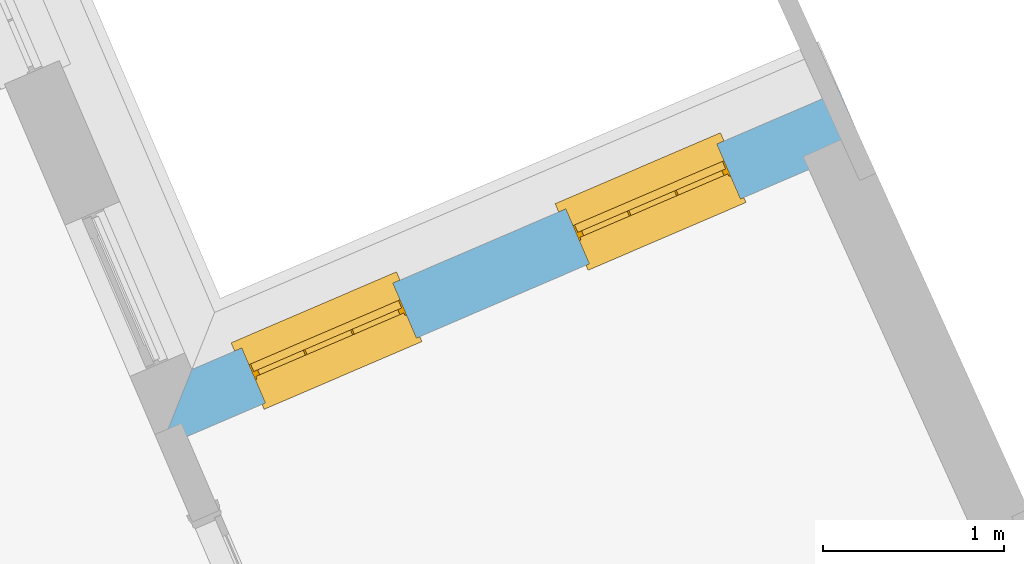
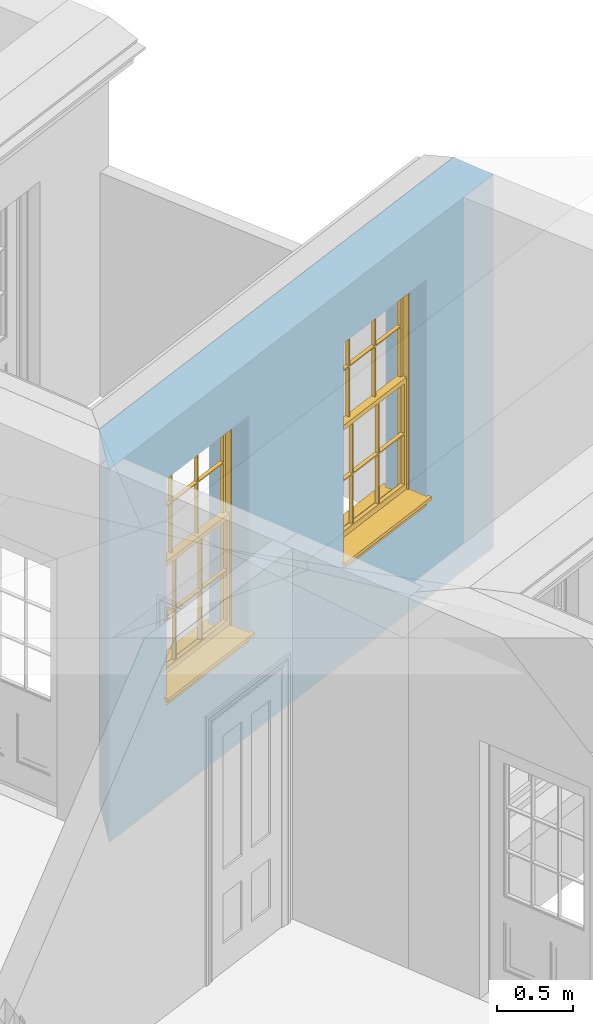
# One storey, part 11 of 19: 2 windows, 2 openings, plus 1 element that does not belong to this part.
"""IFC2X3 building model written with IfcOpenShell, lengths in metres."""

from ifc_helpers import new_model, si_unit, frame, origin, place, context, subcontext, project, spatial, polyline, outline, extrude, faceted_brep, material, layer, layer_set, layer_usage, element, fill, save


model = new_model("IFC2X3")

# Units and contexts
model_context = context("Model", 3, world=origin())
body_context = subcontext(model_context, "Body", "Model", "MODEL_VIEW")
ifc_project = project(units=[si_unit("PLANEANGLEUNIT", "RADIAN"), si_unit("MASSUNIT", "GRAM", prefix="KILO"), si_unit("FORCEUNIT", "NEWTON", prefix="KILO"), si_unit("LENGTHUNIT", "METRE")], contexts=[model_context])

# Site, building, storey
site_placement = place(None, origin())
site = spatial("IfcSite", under=ifc_project, at=site_placement, CompositionType="ELEMENT")
building_placement = place(None, origin())
building = spatial("IfcBuilding", under=site, at=building_placement, Name="Building plot-0", CompositionType="ELEMENT")
storey_placement = place(None, origin())
storey = spatial("IfcBuildingStorey", under=building, at=storey_placement, Name="Floor 0", CompositionType="ELEMENT", Elevation=0.0)

# Wall, openings, windows
ifc_material = material(Name="Masonry")
ifc_layer = layer(ifc_material, 0.33, ventilated=False)
ifc_layer_set = layer_set([ifc_layer], Name="My Wall")
ifc_layer_usage = layer_usage(ifc_layer_set, "AXIS2", "NEGATIVE", 0.08)
wall_placement = place(storey_placement, origin())
wall = element("IfcWallStandardCase", 1, at=wall_placement, inside=storey, material=ifc_layer_usage, Name="exterior", context=body_context, shape_type="SweptSolid", body=[
    extrude(outline(polyline([(25.5111749941771, 31.5294068783981), (25.3809935224059, 31.832644053572), (21.7985578106213, 30.2946836988818), (21.6255021072185, 29.8612650519367), (25.5111749941771, 31.5294068783981)])), origin(), (0.0, 0.0, 1.0), 3.0),
])
opening_1_placement = place(storey_placement, frame((0.0, 0.0, 0.75)))
opening_1 = element("IfcOpeningElement", 2, at=opening_1_placement, cuts=wall, Name="Opening", ObjectType="Opening", context=body_context, shape_type="SweptSolid", body=[
    extrude(outline(polyline([(24.7016453088181, 31.540995939388), (23.8654458257626, 31.1820106687462), (23.9956272975338, 30.8787734935722), (24.8318267805893, 31.237758764214), (24.7016453088181, 31.540995939388)])), origin(), (0.0, 0.0, 1.0), 1.82),
])
opening_2_placement = place(storey_placement, frame((0.0, 0.0, 0.75)))
opening_2 = element("IfcOpeningElement", 3, at=opening_2_placement, cuts=wall, Name="Opening", ObjectType="Opening", context=body_context, shape_type="SweptSolid", body=[
    extrude(outline(polyline([(22.9104274529258, 30.7720157620429), (22.0742279698703, 30.4130304914011), (22.2044094416415, 30.1097933162271), (23.040608924697, 30.4687785868689), (22.9104274529258, 30.7720157620429)])), origin(), (0.0, 0.0, 1.0), 1.82),
])
window_1_placement = place(storey_placement, frame((24.8002676359175, 31.3112708066804, 0.75), z_axis=(0.0, 0.0, 1.0), x_axis=(-0.836199483055477, -0.358985270641778, 0.0)))
window_1 = element("IfcWindow", 4, at=window_1_placement, inside=storey, Name="toilet outside window", OverallHeight=1.82, OverallWidth=0.91, context=body_context, shape_type="Brep", held_by="IfcProductRepresentation", body=[
    faceted_brep([(0.033125, -0.105, 0.975209), (0.01, -0.105, 0.975209), (0.033125, -0.105, 1.376042), (0.876875, -0.105, 0.975209), (0.876875, -0.105, 1.376042), (0.9, -0.105, 0.975209), (0.876875, -0.105, 1.386042), (0.876875, -0.105, 1.786875), (0.9, -0.105, 1.81), (0.033125, -0.105, 1.786875), (0.033125, -0.105, 1.386042), (0.01, -0.105, 1.81), (0.876875, -0.135, 1.376042), (0.876875, -0.135, 0.975209), (0.9, -0.135, 0.937083), (0.033125, -0.135, 1.786875), (0.01, -0.135, 1.81), (0.033125, -0.135, 1.386042), (0.01, -0.135, 0.937083), (0.033125, -0.135, 0.975209), (0.033125, -0.135, 1.376042), (0.876875, -0.135, 1.786875), (0.876875, -0.135, 1.386042), (0.9, -0.135, 1.81), (0.033125, -0.105, 0.937083), (0.01, -0.105, 0.937083), (0.033125, -0.105, 0.53625), (0.876875, -0.105, 0.937083), (0.876875, -0.105, 0.53625), (0.9, -0.105, 0.937083), (0.876875, -0.105, 0.52625), (0.876875, -0.105, 0.125417), (0.9, -0.105, 0.077167), (0.033125, -0.105, 0.125417), (0.033125, -0.105, 0.52625), (0.01, -0.105, 0.077167), (-0.0425, -0.25, 0.01), (-0.0425, -0.3, 0.001667), (0.0, -0.25, 0.01), (0.9525, -0.25, 0.01), (0.91, -0.25, 0.01), (0.9525, -0.3, 0.001667), (-0.02, 0.08, 0.077167), (0.0, 0.08, 0.077167), (-0.02, 0.11, 0.077167), (0.0, -0.06, 0.077167), (0.01, -0.06, 0.077167), (0.91, -0.06, 0.077167), (0.91, 0.08, 0.077167), (0.9, -0.06, 0.077167), (0.93, 0.08, 0.077167), (0.93, 0.11, 0.077167), (0.01, -0.075, 0.975209), (0.9, -0.075, 0.975209), (0.876875, -0.075, 0.125417), (0.876875, -0.075, 0.52625), (0.9, -0.075, 0.077167), (0.876875, -0.075, 0.53625), (0.876875, -0.075, 0.937083), (0.033125, -0.075, 0.125417), (0.01, -0.075, 0.077167), (0.033125, -0.075, 0.52625), (0.033125, -0.075, 0.937083), (0.033125, -0.075, 0.53625), (-0.02, 0.08, 0.052167), (-0.02, 0.11, 0.052167), (0.93, 0.11, 0.052167), (0.93, 0.08, 0.052167), (0.91, 0.08, 0.052167), (0.0, 0.08, 0.052167), (0.91, -0.15, 0.026667), (0.0, -0.15, 0.026667), (-0.0425, -0.3, -0.123333), (0.9525, -0.3, -0.123333), (-0.0425, -0.25, -0.123333), (0.9525, -0.25, -0.123333), (0.01, -0.06, 1.81), (0.9, -0.06, 1.81), (0.0, -0.06, 1.82), (0.91, -0.06, 1.82), (0.01, -0.15, 0.077167), (0.9, -0.15, 0.077167), (0.592292, -0.105, 0.125417), (0.592292, -0.075, 0.125417), (0.317708, -0.075, 0.125417), (0.317708, -0.105, 0.125417), (0.592292, -0.105, 0.53625), (0.317708, -0.105, 0.53625), (0.317708, -0.105, 0.52625), (0.592292, -0.105, 0.52625), (0.592292, -0.075, 0.53625), (0.317708, -0.075, 0.53625), (0.592292, -0.135, 1.386042), (0.592292, -0.105, 1.386042), (0.317708, -0.105, 1.386042), (0.317708, -0.135, 1.386042), (0.317708, -0.135, 1.376042), (0.592292, -0.135, 1.376042), (0.317708, -0.105, 1.376042), (0.592292, -0.105, 1.376042), (0.602292, -0.135, 1.376042), (0.592292, -0.135, 0.975209), (0.602292, -0.135, 0.975209), (0.602292, -0.105, 0.975209), (0.592292, -0.105, 0.975209), (0.602292, -0.105, 1.376042), (0.602292, -0.075, 0.53625), (0.602292, -0.105, 0.53625), (0.317708, -0.075, 0.52625), (0.307708, -0.075, 0.125417), (0.307708, -0.075, 0.52625), (0.602292, -0.075, 0.52625), (0.602292, -0.075, 0.125417), (0.592292, -0.075, 0.52625), (0.307708, -0.075, 0.53625), (0.317708, -0.075, 0.937083), (0.307708, -0.075, 0.937083), (0.602292, -0.075, 0.937083), (0.592292, -0.075, 0.937083), (0.307708, -0.105, 0.52625), (0.307708, -0.105, 0.125417), (0.307708, -0.105, 0.53625), (0.307708, -0.105, 0.937083), (0.592292, -0.105, 0.937083), (0.317708, -0.105, 0.937083), (0.602292, -0.105, 0.937083), (0.602292, -0.105, 0.52625), (0.602292, -0.105, 0.125417), (0.307708, -0.135, 1.386042), (0.307708, -0.135, 1.376042), (0.307708, -0.135, 0.975209), (0.317708, -0.135, 0.975209), (0.317708, -0.135, 1.786875), (0.307708, -0.135, 1.786875), (0.602292, -0.135, 1.786875), (0.592292, -0.135, 1.786875), (0.602292, -0.135, 1.386042), (0.602292, -0.105, 1.386042), (0.307708, -0.105, 1.386042), (0.307708, -0.105, 1.786875), (0.317708, -0.105, 1.786875), (0.592292, -0.105, 1.786875), (0.602292, -0.105, 1.786875), (0.307708, -0.105, 1.376042), (0.317708, -0.105, 0.975209), (0.307708, -0.105, 0.975209), (0.91, -0.15, 1.82), (0.9, -0.15, 1.81), (0.01, -0.15, 1.81), (0.0, -0.15, 1.82), (0.91, -0.25, 0.0), (0.0, -0.25, 0.0), (0.91, 0.08, 0.0), (0.0, 0.08, 0.0)], [[[0, 1, 2]], [[3, 4, 5]], [[6, 7, 8]], [[9, 10, 11]], [[12, 13, 14]], [[15, 16, 17]], [[18, 19, 20]], [[21, 22, 23]], [[24, 25, 26]], [[27, 28, 29]], [[30, 31, 32]], [[33, 34, 35]], [[14, 27, 29]], [[25, 24, 18]], [[36, 37, 38]], [[39, 40, 41]], [[42, 43, 44]], [[45, 46, 43]], [[47, 48, 49]], [[50, 51, 48]], [[1, 0, 52]], [[5, 53, 3]], [[54, 55, 56]], [[57, 58, 53]], [[59, 60, 61]], [[62, 63, 52]], [[48, 43, 46, 49]], [[51, 44, 43, 48]], [[64, 42, 44, 65]], [[65, 44, 51, 66]], [[66, 51, 50, 67]], [[65, 66, 68, 69]], [[60, 56, 49, 46]], [[70, 71, 38, 40]], [[37, 41, 40, 38]], [[37, 72, 73, 41]], [[74, 75, 73, 72]], [[8, 11, 76, 77]], [[76, 78, 79, 77]], [[32, 35, 80, 81]], [[81, 80, 71, 70]], [[82, 83, 84, 85]], [[86, 87, 88, 89]], [[86, 90, 91, 87]], [[92, 93, 94, 95]], [[92, 95, 96, 97]], [[96, 98, 99, 97]], [[100, 97, 101, 102]], [[103, 104, 99, 105]], [[97, 99, 104, 101]], [[102, 103, 105, 100]], [[28, 57, 106, 107]], [[108, 84, 109, 110]], [[111, 112, 83, 113]], [[114, 110, 61, 63]], [[90, 113, 108, 91]], [[115, 91, 114, 116]], [[117, 106, 90, 118]], [[111, 106, 57, 55]], [[119, 110, 109, 120]], [[34, 61, 110, 119]], [[89, 113, 83, 82]], [[88, 108, 113, 89]], [[85, 84, 108, 88]], [[121, 114, 63, 26]], [[122, 116, 114, 121]], [[123, 118, 90, 86]], [[87, 91, 115, 124]], [[107, 106, 117, 125]], [[126, 111, 55, 30]], [[127, 112, 111, 126]], [[126, 30, 28, 107]], [[88, 119, 120, 85]], [[126, 89, 82, 127]], [[125, 123, 86, 107]], [[121, 26, 34, 119]], [[124, 122, 121, 87]], [[128, 17, 20, 129]], [[96, 129, 130, 131]], [[132, 133, 128, 95]], [[134, 135, 92, 136]], [[100, 12, 22, 136]], [[137, 6, 4, 105]], [[94, 138, 139, 140]], [[137, 93, 141, 142]], [[99, 98, 94, 93]], [[143, 2, 10, 138]], [[144, 145, 143, 98]], [[129, 143, 145, 130]], [[20, 2, 143, 129]], [[131, 144, 98, 96]], [[128, 138, 10, 17]], [[133, 139, 138, 128]], [[135, 141, 93, 92]], [[95, 94, 140, 132]], [[22, 6, 137, 136]], [[136, 137, 142, 134]], [[100, 105, 4, 12]], [[107, 86, 89, 126]], [[106, 111, 113, 90]], [[91, 108, 110, 114]], [[87, 121, 119, 88]], [[97, 100, 136, 92]], [[129, 96, 95, 128]], [[98, 143, 138, 94]], [[105, 99, 93, 137]], [[131, 101, 104, 144]], [[124, 115, 118, 123]], [[132, 140, 141, 135]], [[120, 109, 59, 33]], [[15, 9, 139, 133]], [[134, 142, 7, 21]], [[31, 54, 112, 127]], [[36, 74, 72, 37]], [[39, 41, 73, 75]], [[18, 14, 101, 131]], [[23, 16, 132, 135]], [[83, 56, 60, 84]], [[52, 53, 118, 115]], [[53, 52, 144, 104]], [[11, 8, 141, 140]], [[14, 18, 124, 123]], [[2, 1, 11, 10]], [[8, 5, 4, 6]], [[57, 53, 56, 55]], [[60, 52, 63, 61]], [[26, 25, 35, 34]], [[32, 29, 28, 30]], [[14, 23, 22, 12]], [[18, 20, 17, 16]], [[19, 0, 2, 20]], [[17, 10, 9, 15]], [[12, 4, 3, 13]], [[21, 7, 6, 22]], [[27, 58, 57, 28]], [[30, 55, 54, 31]], [[33, 59, 61, 34]], [[26, 63, 62, 24]], [[5, 8, 77, 53]], [[76, 11, 1, 52]], [[46, 45, 78, 76]], [[49, 77, 79, 47]], [[70, 146, 147, 81]], [[71, 80, 148, 149]], [[19, 130, 145, 0]], [[102, 13, 3, 103]], [[116, 122, 24, 62]], [[29, 32, 81, 14]], [[80, 35, 25, 18]], [[60, 46, 76, 52]], [[77, 49, 56, 53]], [[23, 14, 81, 147]], [[16, 148, 80, 18]], [[35, 85, 120]], [[120, 33, 35]], [[127, 82, 32]], [[32, 31, 127]], [[32, 82, 85, 35]], [[102, 101, 14]], [[14, 13, 102]], [[18, 131, 130]], [[130, 19, 18]], [[134, 21, 23]], [[23, 135, 134]], [[16, 15, 133]], [[133, 132, 16]], [[11, 140, 139]], [[139, 9, 11]], [[142, 141, 8]], [[8, 7, 142]], [[23, 147, 148, 16]], [[146, 149, 148, 147]], [[52, 115, 116]], [[116, 62, 52]], [[118, 53, 117]], [[58, 117, 53]], [[27, 125, 117, 58]], [[56, 83, 112]], [[112, 54, 56]], [[109, 84, 60]], [[60, 59, 109]], [[125, 27, 14]], [[14, 123, 125]], [[122, 124, 18]], [[18, 24, 122]], [[145, 144, 52]], [[52, 0, 145]], [[103, 3, 53]], [[53, 104, 103]], [[79, 78, 149, 146]], [[78, 45, 71, 149]], [[146, 70, 47, 79]], [[150, 75, 74, 151]], [[68, 66, 67]], [[48, 68, 67, 50]], [[69, 64, 65]], [[42, 64, 69, 43]], [[69, 68, 152, 153]], [[70, 68, 48, 47]], [[150, 152, 68, 70]], [[43, 69, 71, 45]], [[69, 153, 151, 71]], [[152, 150, 151, 153]], [[38, 151, 74, 36]], [[71, 151, 38]], [[39, 75, 150, 40]], [[40, 150, 70]]]),
])
fill(opening_1, window_1)
window_2_placement = place(storey_placement, frame((23.0090497800252, 30.5422906293353, 0.75), z_axis=(0.0, 0.0, 1.0), x_axis=(-0.836199483055481, -0.358985270641778, 0.0)))
window_2 = element("IfcWindow", 5, at=window_2_placement, inside=storey, Name="toilet outside window", OverallHeight=1.82, OverallWidth=0.91, context=body_context, shape_type="Brep", held_by="IfcProductRepresentation", body=[
    faceted_brep([(0.033125, -0.105, 0.975209), (0.01, -0.105, 0.975209), (0.033125, -0.105, 1.376042), (0.876875, -0.105, 0.975209), (0.876875, -0.105, 1.376042), (0.9, -0.105, 0.975209), (0.876875, -0.105, 1.386042), (0.876875, -0.105, 1.786875), (0.9, -0.105, 1.81), (0.033125, -0.105, 1.786875), (0.033125, -0.105, 1.386042), (0.01, -0.105, 1.81), (0.876875, -0.135, 1.376042), (0.876875, -0.135, 0.975209), (0.9, -0.135, 0.937083), (0.033125, -0.135, 1.786875), (0.01, -0.135, 1.81), (0.033125, -0.135, 1.386042), (0.01, -0.135, 0.937083), (0.033125, -0.135, 0.975209), (0.033125, -0.135, 1.376042), (0.876875, -0.135, 1.786875), (0.876875, -0.135, 1.386042), (0.9, -0.135, 1.81), (0.033125, -0.105, 0.937083), (0.01, -0.105, 0.937083), (0.033125, -0.105, 0.53625), (0.876875, -0.105, 0.937083), (0.876875, -0.105, 0.53625), (0.9, -0.105, 0.937083), (0.876875, -0.105, 0.52625), (0.876875, -0.105, 0.125417), (0.9, -0.105, 0.077167), (0.033125, -0.105, 0.125417), (0.033125, -0.105, 0.52625), (0.01, -0.105, 0.077167), (-0.0425, -0.25, 0.01), (-0.0425, -0.3, 0.001667), (0.0, -0.25, 0.01), (0.9525, -0.25, 0.01), (0.91, -0.25, 0.01), (0.9525, -0.3, 0.001667), (-0.02, 0.08, 0.077167), (0.0, 0.08, 0.077167), (-0.02, 0.11, 0.077167), (0.0, -0.06, 0.077167), (0.01, -0.06, 0.077167), (0.91, -0.06, 0.077167), (0.91, 0.08, 0.077167), (0.9, -0.06, 0.077167), (0.93, 0.08, 0.077167), (0.93, 0.11, 0.077167), (0.01, -0.075, 0.975209), (0.9, -0.075, 0.975209), (0.876875, -0.075, 0.125417), (0.876875, -0.075, 0.52625), (0.9, -0.075, 0.077167), (0.876875, -0.075, 0.53625), (0.876875, -0.075, 0.937083), (0.033125, -0.075, 0.125417), (0.01, -0.075, 0.077167), (0.033125, -0.075, 0.52625), (0.033125, -0.075, 0.937083), (0.033125, -0.075, 0.53625), (-0.02, 0.08, 0.052167), (-0.02, 0.11, 0.052167), (0.93, 0.11, 0.052167), (0.93, 0.08, 0.052167), (0.91, 0.08, 0.052167), (0.0, 0.08, 0.052167), (0.91, -0.15, 0.026667), (0.0, -0.15, 0.026667), (-0.0425, -0.3, -0.123333), (0.9525, -0.3, -0.123333), (-0.0425, -0.25, -0.123333), (0.9525, -0.25, -0.123333), (0.01, -0.06, 1.81), (0.9, -0.06, 1.81), (0.0, -0.06, 1.82), (0.91, -0.06, 1.82), (0.01, -0.15, 0.077167), (0.9, -0.15, 0.077167), (0.592292, -0.105, 0.125417), (0.592292, -0.075, 0.125417), (0.317708, -0.075, 0.125417), (0.317708, -0.105, 0.125417), (0.592292, -0.105, 0.53625), (0.317708, -0.105, 0.53625), (0.317708, -0.105, 0.52625), (0.592292, -0.105, 0.52625), (0.592292, -0.075, 0.53625), (0.317708, -0.075, 0.53625), (0.592292, -0.135, 1.386042), (0.592292, -0.105, 1.386042), (0.317708, -0.105, 1.386042), (0.317708, -0.135, 1.386042), (0.317708, -0.135, 1.376042), (0.592292, -0.135, 1.376042), (0.317708, -0.105, 1.376042), (0.592292, -0.105, 1.376042), (0.602292, -0.135, 1.376042), (0.592292, -0.135, 0.975209), (0.602292, -0.135, 0.975209), (0.602292, -0.105, 0.975209), (0.592292, -0.105, 0.975209), (0.602292, -0.105, 1.376042), (0.602292, -0.075, 0.53625), (0.602292, -0.105, 0.53625), (0.317708, -0.075, 0.52625), (0.307708, -0.075, 0.125417), (0.307708, -0.075, 0.52625), (0.602292, -0.075, 0.52625), (0.602292, -0.075, 0.125417), (0.592292, -0.075, 0.52625), (0.307708, -0.075, 0.53625), (0.317708, -0.075, 0.937083), (0.307708, -0.075, 0.937083), (0.602292, -0.075, 0.937083), (0.592292, -0.075, 0.937083), (0.307708, -0.105, 0.52625), (0.307708, -0.105, 0.125417), (0.307708, -0.105, 0.53625), (0.307708, -0.105, 0.937083), (0.592292, -0.105, 0.937083), (0.317708, -0.105, 0.937083), (0.602292, -0.105, 0.937083), (0.602292, -0.105, 0.52625), (0.602292, -0.105, 0.125417), (0.307708, -0.135, 1.386042), (0.307708, -0.135, 1.376042), (0.307708, -0.135, 0.975209), (0.317708, -0.135, 0.975209), (0.317708, -0.135, 1.786875), (0.307708, -0.135, 1.786875), (0.602292, -0.135, 1.786875), (0.592292, -0.135, 1.786875), (0.602292, -0.135, 1.386042), (0.602292, -0.105, 1.386042), (0.307708, -0.105, 1.386042), (0.307708, -0.105, 1.786875), (0.317708, -0.105, 1.786875), (0.592292, -0.105, 1.786875), (0.602292, -0.105, 1.786875), (0.307708, -0.105, 1.376042), (0.317708, -0.105, 0.975209), (0.307708, -0.105, 0.975209), (0.91, -0.15, 1.82), (0.9, -0.15, 1.81), (0.01, -0.15, 1.81), (0.0, -0.15, 1.82), (0.91, -0.25, 0.0), (0.0, -0.25, 0.0), (0.91, 0.08, 0.0), (0.0, 0.08, 0.0)], [[[0, 1, 2]], [[3, 4, 5]], [[6, 7, 8]], [[9, 10, 11]], [[12, 13, 14]], [[15, 16, 17]], [[18, 19, 20]], [[21, 22, 23]], [[24, 25, 26]], [[27, 28, 29]], [[30, 31, 32]], [[33, 34, 35]], [[14, 27, 29]], [[25, 24, 18]], [[36, 37, 38]], [[39, 40, 41]], [[42, 43, 44]], [[45, 46, 43]], [[47, 48, 49]], [[50, 51, 48]], [[1, 0, 52]], [[5, 53, 3]], [[54, 55, 56]], [[57, 58, 53]], [[59, 60, 61]], [[62, 63, 52]], [[48, 43, 46, 49]], [[51, 44, 43, 48]], [[64, 42, 44, 65]], [[65, 44, 51, 66]], [[66, 51, 50, 67]], [[65, 66, 68, 69]], [[60, 56, 49, 46]], [[70, 71, 38, 40]], [[37, 41, 40, 38]], [[37, 72, 73, 41]], [[74, 75, 73, 72]], [[8, 11, 76, 77]], [[76, 78, 79, 77]], [[32, 35, 80, 81]], [[81, 80, 71, 70]], [[82, 83, 84, 85]], [[86, 87, 88, 89]], [[86, 90, 91, 87]], [[92, 93, 94, 95]], [[92, 95, 96, 97]], [[96, 98, 99, 97]], [[100, 97, 101, 102]], [[103, 104, 99, 105]], [[97, 99, 104, 101]], [[102, 103, 105, 100]], [[28, 57, 106, 107]], [[108, 84, 109, 110]], [[111, 112, 83, 113]], [[114, 110, 61, 63]], [[90, 113, 108, 91]], [[115, 91, 114, 116]], [[117, 106, 90, 118]], [[111, 106, 57, 55]], [[119, 110, 109, 120]], [[34, 61, 110, 119]], [[89, 113, 83, 82]], [[88, 108, 113, 89]], [[85, 84, 108, 88]], [[121, 114, 63, 26]], [[122, 116, 114, 121]], [[123, 118, 90, 86]], [[87, 91, 115, 124]], [[107, 106, 117, 125]], [[126, 111, 55, 30]], [[127, 112, 111, 126]], [[126, 30, 28, 107]], [[88, 119, 120, 85]], [[126, 89, 82, 127]], [[125, 123, 86, 107]], [[121, 26, 34, 119]], [[124, 122, 121, 87]], [[128, 17, 20, 129]], [[96, 129, 130, 131]], [[132, 133, 128, 95]], [[134, 135, 92, 136]], [[100, 12, 22, 136]], [[137, 6, 4, 105]], [[94, 138, 139, 140]], [[137, 93, 141, 142]], [[99, 98, 94, 93]], [[143, 2, 10, 138]], [[144, 145, 143, 98]], [[129, 143, 145, 130]], [[20, 2, 143, 129]], [[131, 144, 98, 96]], [[128, 138, 10, 17]], [[133, 139, 138, 128]], [[135, 141, 93, 92]], [[95, 94, 140, 132]], [[22, 6, 137, 136]], [[136, 137, 142, 134]], [[100, 105, 4, 12]], [[107, 86, 89, 126]], [[106, 111, 113, 90]], [[91, 108, 110, 114]], [[87, 121, 119, 88]], [[97, 100, 136, 92]], [[129, 96, 95, 128]], [[98, 143, 138, 94]], [[105, 99, 93, 137]], [[131, 101, 104, 144]], [[124, 115, 118, 123]], [[132, 140, 141, 135]], [[120, 109, 59, 33]], [[15, 9, 139, 133]], [[134, 142, 7, 21]], [[31, 54, 112, 127]], [[36, 74, 72, 37]], [[39, 41, 73, 75]], [[18, 14, 101, 131]], [[23, 16, 132, 135]], [[83, 56, 60, 84]], [[52, 53, 118, 115]], [[53, 52, 144, 104]], [[11, 8, 141, 140]], [[14, 18, 124, 123]], [[2, 1, 11, 10]], [[8, 5, 4, 6]], [[57, 53, 56, 55]], [[60, 52, 63, 61]], [[26, 25, 35, 34]], [[32, 29, 28, 30]], [[14, 23, 22, 12]], [[18, 20, 17, 16]], [[19, 0, 2, 20]], [[17, 10, 9, 15]], [[12, 4, 3, 13]], [[21, 7, 6, 22]], [[27, 58, 57, 28]], [[30, 55, 54, 31]], [[33, 59, 61, 34]], [[26, 63, 62, 24]], [[5, 8, 77, 53]], [[76, 11, 1, 52]], [[46, 45, 78, 76]], [[49, 77, 79, 47]], [[70, 146, 147, 81]], [[71, 80, 148, 149]], [[19, 130, 145, 0]], [[102, 13, 3, 103]], [[116, 122, 24, 62]], [[29, 32, 81, 14]], [[80, 35, 25, 18]], [[60, 46, 76, 52]], [[77, 49, 56, 53]], [[23, 14, 81, 147]], [[16, 148, 80, 18]], [[35, 85, 120]], [[120, 33, 35]], [[127, 82, 32]], [[32, 31, 127]], [[32, 82, 85, 35]], [[102, 101, 14]], [[14, 13, 102]], [[18, 131, 130]], [[130, 19, 18]], [[134, 21, 23]], [[23, 135, 134]], [[16, 15, 133]], [[133, 132, 16]], [[11, 140, 139]], [[139, 9, 11]], [[142, 141, 8]], [[8, 7, 142]], [[23, 147, 148, 16]], [[146, 149, 148, 147]], [[52, 115, 116]], [[116, 62, 52]], [[118, 53, 117]], [[58, 117, 53]], [[27, 125, 117, 58]], [[56, 83, 112]], [[112, 54, 56]], [[109, 84, 60]], [[60, 59, 109]], [[125, 27, 14]], [[14, 123, 125]], [[122, 124, 18]], [[18, 24, 122]], [[145, 144, 52]], [[52, 0, 145]], [[103, 3, 53]], [[53, 104, 103]], [[79, 78, 149, 146]], [[78, 45, 71, 149]], [[146, 70, 47, 79]], [[150, 75, 74, 151]], [[68, 66, 67]], [[48, 68, 67, 50]], [[69, 64, 65]], [[42, 64, 69, 43]], [[69, 68, 152, 153]], [[70, 68, 48, 47]], [[150, 152, 68, 70]], [[43, 69, 71, 45]], [[69, 153, 151, 71]], [[152, 150, 151, 153]], [[38, 151, 74, 36]], [[71, 151, 38]], [[39, 75, 150, 40]], [[40, 150, 70]]]),
])
fill(opening_2, window_2)

save(model, "model.ifc")
